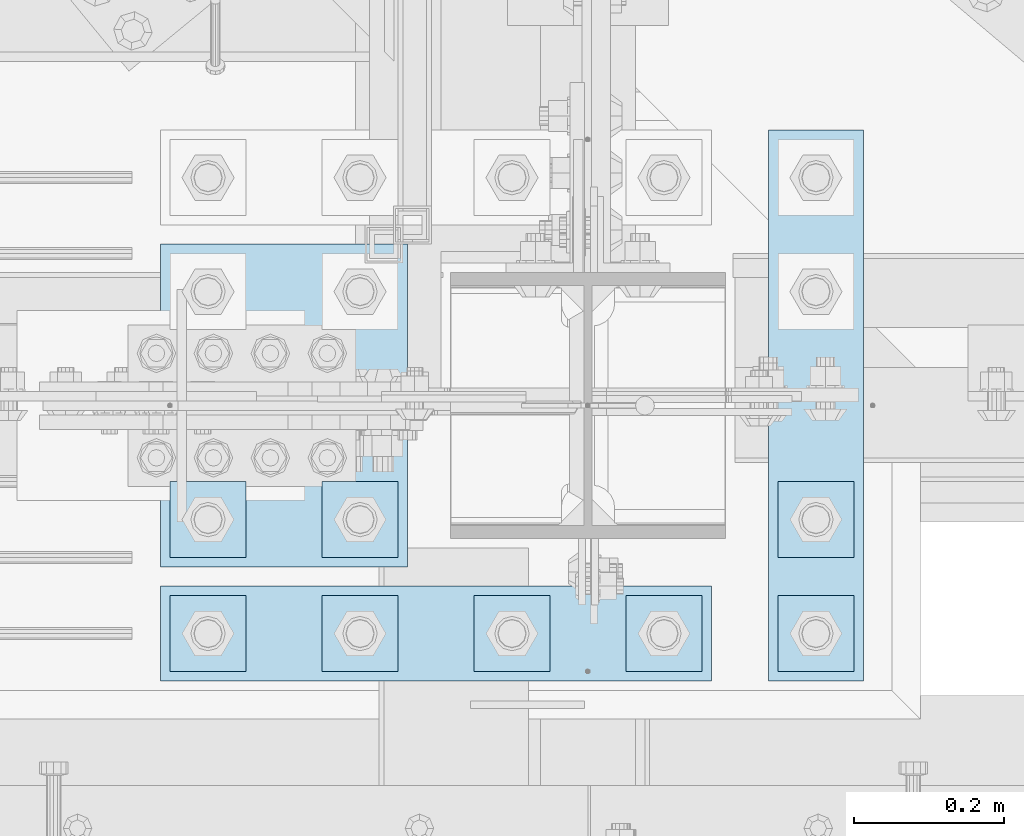
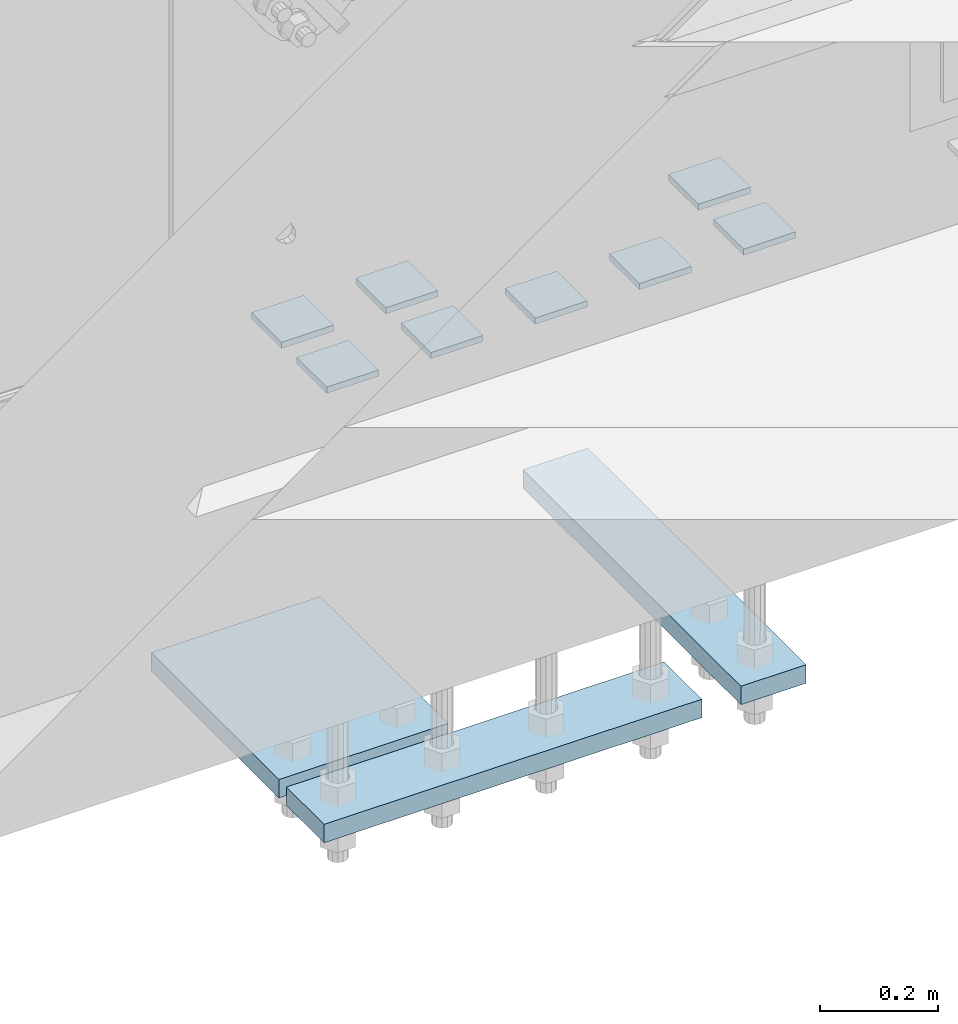
# One storey, part 3137 of 3843: 11 plates, 1 element without a shape of its own.
"""IFC2X3 building model written with IfcOpenShell, lengths in millimetres."""

from ifc_helpers import new_model, si_unit, frame, origin_with_axes, place, context, subcontext, project, spatial, faceted_brep, material, type_object, element, aggregate, save


model = new_model("IFC2X3")

# Units and contexts
model_context = context("Model", 3, precision=1e-05, world=origin_with_axes())
body_context = subcontext(model_context, "Body", "Model", "MODEL_VIEW")
ifc_project = project(units=[si_unit("LENGTHUNIT", "METRE", prefix="MILLI"), si_unit("AREAUNIT", "SQUARE_METRE"), si_unit("VOLUMEUNIT", "CUBIC_METRE"), si_unit("MASSUNIT", "GRAM", prefix="KILO"), si_unit("TIMEUNIT", "SECOND"), si_unit("PLANEANGLEUNIT", "RADIAN"), si_unit("SOLIDANGLEUNIT", "STERADIAN"), si_unit("THERMODYNAMICTEMPERATUREUNIT", "DEGREE_CELSIUS"), si_unit("LUMINOUSINTENSITYUNIT", "LUMEN")], contexts=[model_context])

# Site, building, storey
site_placement = place(None, origin_with_axes())
site = spatial("IfcSite", under=ifc_project, at=site_placement, CompositionType="ELEMENT")
building_placement = place(site_placement, origin_with_axes())
building = spatial("IfcBuilding", under=site, at=building_placement, Name="Undefined", CompositionType="ELEMENT")
storey_placement = place(building_placement, origin_with_axes())
storey = spatial("IfcBuildingStorey", under=building, at=storey_placement, Name="Undefined", CompositionType="ELEMENT", Elevation=0.0)

# Assembly, plates
assembly_placement = place(storey_placement, origin_with_axes())
assembly = element("IfcElementAssembly", 1, at=assembly_placement, inside=storey, Name="TEMPLATE", AssemblyPlace="NOTDEFINED", PredefinedType="RIGID_FRAME")
ifc_material = material(Name="STEEL/A572-50")
plate_type_1 = type_object("IfcPlateType", PredefinedType="NOTDEFINED")
plate_1_placement = place(assembly_placement, frame((48539.4, 25361.9, 29686.25), z_axis=(-1.0, 0.0, 0.0), x_axis=(0.0, -1.0, 0.0)))
plate_1 = element("IfcPlate", 2, at=plate_1_placement, type_object=plate_type_1, material=ifc_material, Name="Washer Plate", context=body_context, shape_type="Brep", body=[
    faceted_brep([(0.0, -6.3499999046162, 0.0), (-1.67347025126219e-10, -6.35000000000582, 101.600000000151), (-1.67347025126219e-10, 6.35000000000582, 101.600000000151), (7.27595761418343e-12, 6.3499999046162, 0.0), (101.599998474121, -6.34999999999854, 101.599998474121), (101.599998474121, 6.34999999999854, 101.599998474121), (101.6, -6.34999999999854, 0.0), (101.6, 6.34999999999854, 0.0)], [[[0, 1, 2, 3]], [[1, 4, 5, 2]], [[4, 6, 7, 5]], [[6, 0, 3, 7]], [[5, 7, 3, 2]], [[6, 4, 1, 0]]]),
])
plate_2_placement = place(assembly_placement, frame((48742.6, 25361.9, 29686.25), z_axis=(-1.0, 0.0, 0.0), x_axis=(0.0, -1.0, 0.0)))
plate_2 = element("IfcPlate", 3, at=plate_2_placement, type_object=plate_type_1, material=ifc_material, Name="Washer Plate", context=body_context, shape_type="Brep", body=[
    faceted_brep([(0.0, -6.3499999046162, 0.0), (-1.67347025126219e-10, -6.35000000000582, 101.600000000151), (-1.67347025126219e-10, 6.35000000000582, 101.600000000151), (7.27595761418343e-12, 6.3499999046162, 0.0), (101.599998474121, -6.34999999999854, 101.599998474121), (101.599998474121, 6.34999999999854, 101.599998474121), (101.6, -6.34999999999854, 0.0), (101.6, 6.34999999999854, 0.0)], [[[0, 1, 2, 3]], [[1, 4, 5, 2]], [[4, 6, 7, 5]], [[6, 0, 3, 7]], [[5, 7, 3, 2]], [[6, 4, 1, 0]]]),
])
plate_3_placement = place(assembly_placement, frame((48945.8, 25361.9, 29686.25), z_axis=(-1.0, 0.0, 0.0), x_axis=(0.0, -1.0, 0.0)))
plate_3 = element("IfcPlate", 4, at=plate_3_placement, type_object=plate_type_1, material=ifc_material, Name="Washer Plate", context=body_context, shape_type="Brep", body=[
    faceted_brep([(0.0, -6.3499999046162, 0.0), (-1.67347025126219e-10, -6.35000000000582, 101.600000000151), (-1.67347025126219e-10, 6.35000000000582, 101.600000000151), (7.27595761418343e-12, 6.3499999046162, 0.0), (101.599998474121, -6.34999999999854, 101.599998474121), (101.599998474121, 6.34999999999854, 101.599998474121), (101.6, -6.34999999999854, 0.0), (101.6, 6.34999999999854, 0.0)], [[[0, 1, 2, 3]], [[1, 4, 5, 2]], [[4, 6, 7, 5]], [[6, 0, 3, 7]], [[5, 7, 3, 2]], [[6, 4, 1, 0]]]),
])
plate_4_placement = place(assembly_placement, frame((49149.0, 25361.9, 29686.25), z_axis=(-1.0, 0.0, 0.0), x_axis=(0.0, -1.0, 0.0)))
plate_4 = element("IfcPlate", 5, at=plate_4_placement, type_object=plate_type_1, material=ifc_material, Name="Washer Plate", context=body_context, shape_type="Brep", body=[
    faceted_brep([(0.0, -6.3499999046162, 0.0), (-1.67347025126219e-10, -6.35000000000582, 101.600000000151), (-1.67347025126219e-10, 6.35000000000582, 101.600000000151), (7.27595761418343e-12, 6.3499999046162, 0.0), (101.599998474121, -6.34999999999854, 101.599998474121), (101.599998474121, 6.34999999999854, 101.599998474121), (101.6, -6.34999999999854, 0.0), (101.6, 6.34999999999854, 0.0)], [[[0, 1, 2, 3]], [[1, 4, 5, 2]], [[4, 6, 7, 5]], [[6, 0, 3, 7]], [[5, 7, 3, 2]], [[6, 4, 1, 0]]]),
])
plate_5_placement = place(assembly_placement, frame((49352.2, 25361.9, 29686.25), z_axis=(-1.0, 0.0, 0.0), x_axis=(0.0, -1.0, 0.0)))
plate_5 = element("IfcPlate", 6, at=plate_5_placement, type_object=plate_type_1, material=ifc_material, Name="Washer Plate", context=body_context, shape_type="Brep", body=[
    faceted_brep([(0.0, -6.3499999046162, 0.0), (-1.67347025126219e-10, -6.35000000000582, 101.600000000151), (-1.67347025126219e-10, 6.35000000000582, 101.600000000151), (7.27595761418343e-12, 6.3499999046162, 0.0), (101.599998474121, -6.34999999999854, 101.599998474121), (101.599998474121, 6.34999999999854, 101.599998474121), (101.6, -6.34999999999854, 0.0), (101.6, 6.34999999999854, 0.0)], [[[0, 1, 2, 3]], [[1, 4, 5, 2]], [[4, 6, 7, 5]], [[6, 0, 3, 7]], [[5, 7, 3, 2]], [[6, 4, 1, 0]]]),
])
plate_6_placement = place(assembly_placement, frame((48539.4, 25514.3, 29686.25), z_axis=(-1.0, 0.0, 0.0), x_axis=(0.0, -1.0, 0.0)))
plate_6 = element("IfcPlate", 7, at=plate_6_placement, type_object=plate_type_1, material=ifc_material, Name="Washer Plate", context=body_context, shape_type="Brep", body=[
    faceted_brep([(0.0, -6.3499999046162, 0.0), (-1.67347025126219e-10, -6.35000000000582, 101.600000000151), (-1.67347025126219e-10, 6.35000000000582, 101.600000000151), (7.27595761418343e-12, 6.3499999046162, 0.0), (101.599998474121, -6.34999999999854, 101.599998474121), (101.599998474121, 6.34999999999854, 101.599998474121), (101.6, -6.34999999999854, 0.0), (101.6, 6.34999999999854, 0.0)], [[[0, 1, 2, 3]], [[1, 4, 5, 2]], [[4, 6, 7, 5]], [[6, 0, 3, 7]], [[5, 7, 3, 2]], [[6, 4, 1, 0]]]),
])
plate_7_placement = place(assembly_placement, frame((48742.6, 25514.3, 29686.25), z_axis=(-1.0, 0.0, 0.0), x_axis=(0.0, -1.0, 0.0)))
plate_7 = element("IfcPlate", 8, at=plate_7_placement, type_object=plate_type_1, material=ifc_material, Name="Washer Plate", context=body_context, shape_type="Brep", body=[
    faceted_brep([(0.0, -6.3499999046162, 0.0), (-1.67347025126219e-10, -6.35000000000582, 101.600000000151), (-1.67347025126219e-10, 6.35000000000582, 101.600000000151), (7.27595761418343e-12, 6.3499999046162, 0.0), (101.599998474121, -6.34999999999854, 101.599998474121), (101.599998474121, 6.34999999999854, 101.599998474121), (101.6, -6.34999999999854, 0.0), (101.6, 6.34999999999854, 0.0)], [[[0, 1, 2, 3]], [[1, 4, 5, 2]], [[4, 6, 7, 5]], [[6, 0, 3, 7]], [[5, 7, 3, 2]], [[6, 4, 1, 0]]]),
])
plate_8_placement = place(assembly_placement, frame((49352.2, 25514.3, 29686.25), z_axis=(-1.0, 0.0, 0.0), x_axis=(0.0, -1.0, 0.0)))
plate_8 = element("IfcPlate", 9, at=plate_8_placement, type_object=plate_type_1, material=ifc_material, Name="Washer Plate", context=body_context, shape_type="Brep", body=[
    faceted_brep([(0.0, -6.3499999046162, 0.0), (-1.67347025126219e-10, -6.35000000000582, 101.600000000151), (-1.67347025126219e-10, 6.35000000000582, 101.600000000151), (7.27595761418343e-12, 6.3499999046162, 0.0), (101.599998474121, -6.34999999999854, 101.599998474121), (101.599998474121, 6.34999999999854, 101.599998474121), (101.6, -6.34999999999854, 0.0), (101.6, 6.34999999999854, 0.0)], [[[0, 1, 2, 3]], [[1, 4, 5, 2]], [[4, 6, 7, 5]], [[6, 0, 3, 7]], [[5, 7, 3, 2]], [[6, 4, 1, 0]]]),
])
plate_type_2 = type_object("IfcPlateType", PredefinedType="NOTDEFINED")
plate_9_placement = place(assembly_placement, frame((49364.9, 25984.2, 28784.55), z_axis=(-1.0, 0.0, 0.0), x_axis=(0.0, -1.0, 0.0)))
plate_9 = element("IfcPlate", 10, at=plate_9_placement, type_object=plate_type_2, material=ifc_material, Name="PLATE", context=body_context, shape_type="Brep", body=[
    faceted_brep([(0.0, -19.0500000000029, 0.0), (0.0, -19.0499999999993, 127.0), (0.0, 19.0499999999993, 127.0), (0.0, 19.0500000000029, 0.0), (736.599975585938, -19.0499999999993, 127.0), (736.599975585938, 19.0499999999993, 127.0), (736.599975585938, -19.0499999999993, 0.0), (736.599975585938, 19.0499999999993, 0.0)], [[[0, 1, 2, 3]], [[1, 4, 5, 2]], [[4, 6, 7, 5]], [[6, 0, 3, 7]], [[5, 7, 3, 2]], [[6, 4, 1, 0]]]),
])
plate_10_placement = place(assembly_placement, frame((49161.7, 25374.6, 28784.55), z_axis=(-1.0, 0.0, 0.0), x_axis=(0.0, -1.0, 0.0)))
plate_10 = element("IfcPlate", 11, at=plate_10_placement, type_object=plate_type_2, material=ifc_material, Name="PLATE", context=body_context, shape_type="Brep", body=[
    faceted_brep([(0.0, -19.0500000000029, 0.0), (0.0, -19.0499999999993, 736.600036621094), (0.0, 19.0499999999993, 736.600036621094), (0.0, 19.0500000000029, 0.0), (127.0, -19.0499999999993, 736.600036621094), (127.0, 19.0499999999993, 736.600036621094), (127.0, -19.0499999999993, 0.0), (127.0, 19.0499999999993, 0.0)], [[[0, 1, 2, 3]], [[1, 4, 5, 2]], [[4, 6, 7, 5]], [[6, 0, 3, 7]], [[5, 7, 3, 2]], [[6, 4, 1, 0]]]),
])
plate_type_3 = type_object("IfcPlateType", PredefinedType="NOTDEFINED")
plate_11_placement = place(assembly_placement, frame((48755.3, 25831.8, 28784.55), z_axis=(-1.0, 0.0, 0.0), x_axis=(0.0, -1.0, 0.0)))
plate_11 = element("IfcPlate", 12, at=plate_11_placement, type_object=plate_type_3, material=ifc_material, Name="PLATE", context=body_context, shape_type="Brep", body=[
    faceted_brep([(0.0, -19.0500000000029, 0.0), (0.0, -19.0499999999993, 330.200012207031), (0.0, 19.0499999999993, 330.200012207031), (0.0, 19.0500000000029, 0.0), (431.799957275391, -19.0499999999993, 330.200012207031), (431.799957275391, 19.0499999999993, 330.200012207031), (431.799957275391, -19.0499999999993, 0.0), (431.799957275391, 19.0499999999993, 0.0)], [[[0, 1, 2, 3]], [[1, 4, 5, 2]], [[4, 6, 7, 5]], [[6, 0, 3, 7]], [[5, 7, 3, 2]], [[6, 4, 1, 0]]]),
])
aggregate(assembly, [plate_9, plate_11, plate_10, plate_1, plate_2, plate_3, plate_4, plate_5, plate_6, plate_7, plate_8])

save(model, "model.ifc")
